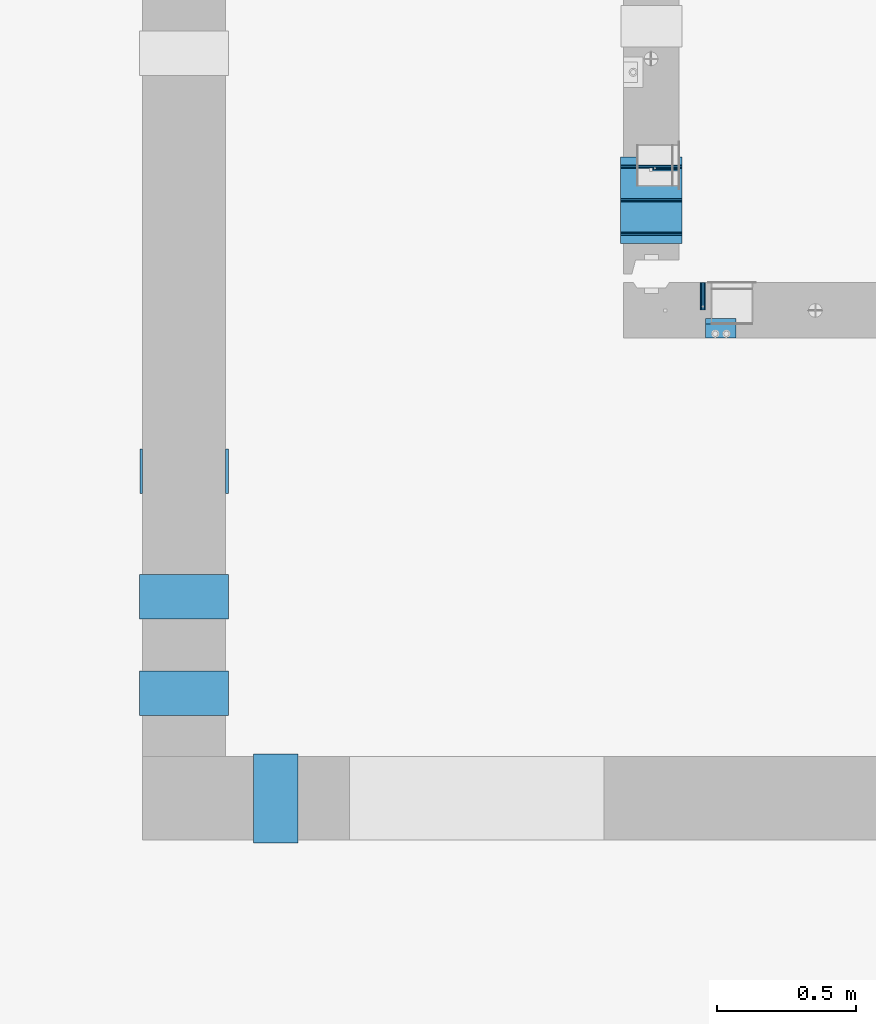
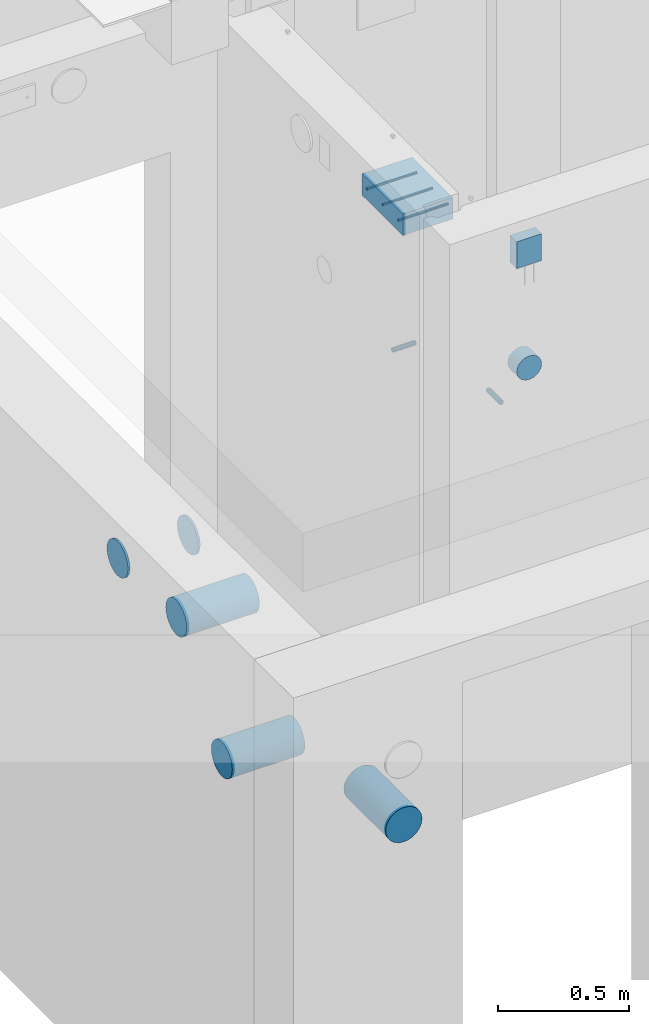
# One storey, part 88 of 264: 12 beams, 8 elements without a shape of their own.
"""IFC2X3 building model written with IfcOpenShell, lengths in millimetres."""

from ifc_helpers import new_model, si_unit, frame, origin_with_axes, place, context, subcontext, project, spatial, faceted_brep, material, type_object, element, aggregate, save


model = new_model("IFC2X3")

# Units and contexts
model_context = context("Model", 3, precision=1e-05, world=origin_with_axes())
body_context = subcontext(model_context, "Body", "Model", "MODEL_VIEW")
ifc_project = project(units=[si_unit("LENGTHUNIT", "METRE", prefix="MILLI"), si_unit("AREAUNIT", "SQUARE_METRE"), si_unit("VOLUMEUNIT", "CUBIC_METRE"), si_unit("MASSUNIT", "GRAM", prefix="KILO"), si_unit("TIMEUNIT", "SECOND"), si_unit("PLANEANGLEUNIT", "RADIAN"), si_unit("SOLIDANGLEUNIT", "STERADIAN"), si_unit("THERMODYNAMICTEMPERATUREUNIT", "DEGREE_CELSIUS"), si_unit("LUMINOUSINTENSITYUNIT", "LUMEN")], contexts=[model_context])

# Site, building, storey
site_placement = place(None, origin_with_axes())
site = spatial("IfcSite", under=ifc_project, at=site_placement, CompositionType="ELEMENT")
building_placement = place(site_placement, origin_with_axes())
building = spatial("IfcBuilding", under=site, at=building_placement, CompositionType="ELEMENT")
storey_placement = place(building_placement, origin_with_axes())
storey = spatial("IfcBuildingStorey", under=building, at=storey_placement, Name="K", CompositionType="ELEMENT", Elevation=0.0)

# Assemblies, beam
assembly_1_placement = place(storey_placement, origin_with_axes())
assembly_1 = element("IfcElementAssembly", 1, at=assembly_1_placement, inside=storey, AssemblyPlace="NOTDEFINED", PredefinedType="REINFORCEMENT_UNIT")
assembly_2_placement = place(assembly_1_placement, origin_with_axes())
assembly_2 = element("IfcElementAssembly", 2, at=assembly_2_placement, Name="Steel Assembly", AssemblyPlace="NOTDEFINED", PredefinedType="RIGID_FRAME")
ifc_material_1 = material(Name="STEEL/Steel_Undefined")
beam_type_1 = type_object("IfcBeamType", PredefinedType="NOTDEFINED")
beam_1_placement = place(assembly_2_placement, frame((15415.0048453854, 15280.0, 80575.0), z_axis=(-1.0, 3.00000001838171e-08, 0.0), x_axis=(0.0, -1.0, 0.0)))
beam_1 = element("IfcBeam", 3, at=beam_1_placement, type_object=beam_type_1, material=ifc_material_1, Name="M16", context=body_context, shape_type="Brep", body=[
    faceted_brep([(0.0, -8.49999999999272, -1.45519152283669e-11), (0.0, -7.36121593215648, 4.24999999998545), (100.000000000262, -7.36121593215648, 4.24999999998545), (100.000000000262, -8.49999999999272, -1.45519152283669e-11), (0.0, -4.24999999998545, 7.36121593216376), (100.000000000262, -4.24999999998545, 7.36121593216376), (0.0, 1.45519152283669e-11, 8.49999999998545), (100.000000000262, 1.45519152283669e-11, 8.49999999998545), (0.0, 4.25000000001455, 7.36121593216376), (100.000000000262, 4.25000000001455, 7.36121593216376), (0.0, 7.36121593217104, 4.24999999998545), (100.000000000262, 7.36121593217104, 4.24999999998545), (0.0, 8.50000000000728, 0.0), (100.000000000262, 8.50000000000728, 0.0), (0.0, 7.36121593217104, -4.25000000001455), (100.000000000262, 7.36121593217104, -4.25000000001455), (0.0, 4.25000000000728, -7.36121593219286), (100.000000000262, 4.25000000000728, -7.36121593219286), (0.0, 7.27595761418343e-12, -8.5), (100.000000000262, 7.27595761418343e-12, -8.5), (0.0, -4.24999999999272, -7.36121593217831), (100.000000000262, -4.24999999999272, -7.36121593217831), (0.0, -7.36121593215648, -4.25), (100.000000000262, -7.36121593215648, -4.25), (0.0, -10.4999999999927, -1.45519152283669e-11), (0.0, -9.09326673972828, -5.25000000001455), (100.000000000262, -9.09326673972828, -5.25000000001455), (100.000000000262, -10.4999999999927, -1.45519152283669e-11), (0.0, -5.24999999998545, -9.09326673974283), (100.000000000262, -5.24999999998545, -9.09326673974283), (0.0, 7.27595761418343e-12, -10.5), (100.000000000262, 7.27595761418343e-12, -10.5), (0.0, 5.25000000001455, -9.09326673975738), (100.000000000262, 5.25000000001455, -9.09326673975738), (0.0, 9.09326673975011, -5.25000000001455), (100.000000000262, 9.09326673975011, -5.25000000001455), (0.0, 10.5000000000073, -1.45519152283669e-11), (100.000000000262, 10.5000000000073, -1.45519152283669e-11), (0.0, 9.09326673975011, 5.25), (100.000000000262, 9.09326673975011, 5.25), (0.0, 5.25000000000728, 9.09326673972828), (100.000000000262, 5.25000000000728, 9.09326673972828), (0.0, 1.45519152283669e-11, 10.4999999999854), (100.000000000262, 1.45519152283669e-11, 10.4999999999854), (0.0, -5.24999999999272, 9.09326673972828), (100.000000000262, -5.24999999999272, 9.09326673972828), (0.0, -9.09326673972828, 5.24999999998545), (100.000000000262, -9.09326673972828, 5.24999999998545)], [[[0, 1, 2, 3]], [[1, 4, 5, 2]], [[4, 6, 7, 5]], [[6, 8, 9, 7]], [[8, 10, 11, 9]], [[10, 12, 13, 11]], [[12, 14, 15, 13]], [[14, 16, 17, 15]], [[16, 18, 19, 17]], [[18, 20, 21, 19]], [[20, 22, 23, 21]], [[22, 0, 3, 23]], [[24, 25, 26, 27]], [[25, 28, 29, 26]], [[28, 30, 31, 29]], [[30, 32, 33, 31]], [[32, 34, 35, 33]], [[34, 36, 37, 35]], [[36, 38, 39, 37]], [[38, 40, 41, 39]], [[40, 42, 43, 41]], [[42, 44, 45, 43]], [[44, 46, 47, 45]], [[46, 24, 27, 47]], [[29, 31, 33, 35, 37, 39, 41, 43, 45, 47, 27, 26], [5, 7, 9, 11, 13, 15, 17, 19, 21, 23, 3, 2]], [[46, 44, 42, 40, 38, 36, 34, 32, 30, 28, 25, 24], [22, 20, 18, 16, 14, 12, 10, 8, 6, 4, 1, 0]]]),
])
aggregate(assembly_2, [beam_1])

assembly_3_placement = place(storey_placement, origin_with_axes())
assembly_3 = element("IfcElementAssembly", 4, at=assembly_3_placement, inside=storey, AssemblyPlace="NOTDEFINED", PredefinedType="REINFORCEMENT_UNIT")
assembly_4_placement = place(assembly_3_placement, origin_with_axes())
assembly_4 = element("IfcElementAssembly", 5, at=assembly_4_placement, Name="Steel Assembly", AssemblyPlace="NOTDEFINED", PredefinedType="RIGID_FRAME")
beam_2_placement = place(assembly_4_placement, frame((15330.0, 15690.0024625975, 80575.0), z_axis=(0.0, -1.0, 0.0), x_axis=(-1.0, 3.00000001838171e-08, 0.0)))
beam_2 = element("IfcBeam", 6, at=beam_2_placement, type_object=beam_type_1, material=ifc_material_1, Name="M16", context=body_context, shape_type="Brep", body=[
    faceted_brep([(0.0, -8.49999999999272, -1.45519152283669e-11), (0.0, -7.36121593215648, 4.24999999998545), (100.000000000262, -7.36121593215648, 4.24999999998545), (100.000000000262, -8.49999999999272, -1.45519152283669e-11), (0.0, -4.24999999998545, 7.36121593216376), (100.000000000262, -4.24999999998545, 7.36121593216376), (0.0, 1.45519152283669e-11, 8.49999999998545), (100.000000000262, 1.45519152283669e-11, 8.49999999998545), (0.0, 4.25000000001455, 7.36121593216376), (100.000000000262, 4.25000000001455, 7.36121593216376), (0.0, 7.36121593217104, 4.24999999998545), (100.000000000262, 7.36121593217104, 4.24999999998545), (0.0, 8.50000000000728, 0.0), (100.000000000262, 8.50000000000728, 0.0), (0.0, 7.36121593217104, -4.25000000001455), (100.000000000262, 7.36121593217104, -4.25000000001455), (0.0, 4.25000000000728, -7.36121593219286), (100.000000000262, 4.25000000000728, -7.36121593219286), (0.0, 7.27595761418343e-12, -8.5), (100.000000000262, 7.27595761418343e-12, -8.5), (0.0, -4.24999999999272, -7.36121593217831), (100.000000000262, -4.24999999999272, -7.36121593217831), (0.0, -7.36121593215648, -4.25), (100.000000000262, -7.36121593215648, -4.25), (0.0, -10.4999999999927, -1.45519152283669e-11), (0.0, -9.09326673972828, -5.25000000001455), (100.000000000262, -9.09326673972828, -5.25000000001455), (100.000000000262, -10.4999999999927, -1.45519152283669e-11), (0.0, -5.24999999998545, -9.09326673974283), (100.000000000262, -5.24999999998545, -9.09326673974283), (0.0, 7.27595761418343e-12, -10.5), (100.000000000262, 7.27595761418343e-12, -10.5), (0.0, 5.25000000001455, -9.09326673975738), (100.000000000262, 5.25000000001455, -9.09326673975738), (0.0, 9.09326673975011, -5.25000000001455), (100.000000000262, 9.09326673975011, -5.25000000001455), (0.0, 10.5000000000073, -1.45519152283669e-11), (100.000000000262, 10.5000000000073, -1.45519152283669e-11), (0.0, 9.09326673975011, 5.25), (100.000000000262, 9.09326673975011, 5.25), (0.0, 5.25000000000728, 9.09326673972828), (100.000000000262, 5.25000000000728, 9.09326673972828), (0.0, 1.45519152283669e-11, 10.4999999999854), (100.000000000262, 1.45519152283669e-11, 10.4999999999854), (0.0, -5.24999999999272, 9.09326673972828), (100.000000000262, -5.24999999999272, 9.09326673972828), (0.0, -9.09326673972828, 5.24999999998545), (100.000000000262, -9.09326673972828, 5.24999999998545)], [[[0, 1, 2, 3]], [[1, 4, 5, 2]], [[4, 6, 7, 5]], [[6, 8, 9, 7]], [[8, 10, 11, 9]], [[10, 12, 13, 11]], [[12, 14, 15, 13]], [[14, 16, 17, 15]], [[16, 18, 19, 17]], [[18, 20, 21, 19]], [[20, 22, 23, 21]], [[22, 0, 3, 23]], [[24, 25, 26, 27]], [[25, 28, 29, 26]], [[28, 30, 31, 29]], [[30, 32, 33, 31]], [[32, 34, 35, 33]], [[34, 36, 37, 35]], [[36, 38, 39, 37]], [[38, 40, 41, 39]], [[40, 42, 43, 41]], [[42, 44, 45, 43]], [[44, 46, 47, 45]], [[46, 24, 27, 47]], [[29, 31, 33, 35, 37, 39, 41, 43, 45, 47, 27, 26], [5, 7, 9, 11, 13, 15, 17, 19, 21, 23, 3, 2]], [[46, 44, 42, 40, 38, 36, 34, 32, 30, 28, 25, 24], [22, 20, 18, 16, 14, 12, 10, 8, 6, 4, 1, 0]]]),
])
aggregate(assembly_4, [beam_2])

# Beam
ifc_material_2 = material()
beam_type_2 = type_object("IfcBeamType", Name="D110", PredefinedType="NOTDEFINED")
beam_3_placement = place(assembly_1_placement, frame((15480.0015915445, 15080.0, 80775.0), z_axis=(0.0, 0.0, 1.0), x_axis=(0.0, 1.0, 0.0)))
beam_3 = element("IfcBeam", 7, at=beam_3_placement, type_object=beam_type_2, material=ifc_material_2, ObjectType="D110", context=body_context, shape_type="Brep", body=[
    faceted_brep([(0.0, -55.0, 0.0), (0.0, -52.3081083962352, -16.9959346906253), (70.0, -52.3081083962352, -16.9959346906253), (70.0, -55.0, 0.0), (0.0, -44.4959346906217, -32.328188876083), (70.0, -44.4959346906217, -32.328188876083), (0.0, -32.3281888760866, -44.4959346906253), (70.0, -32.3281888760866, -44.4959346906253), (0.0, -16.9959346906217, -52.3081083962315), (70.0, -16.9959346906217, -52.3081083962315), (0.0, 0.0, -55.0), (70.0, 0.0, -55.0), (0.0, 16.9959346906217, -52.3081083962315), (70.0, 16.9959346906217, -52.3081083962315), (0.0, 32.3281888760866, -44.4959346906253), (70.0, 32.3281888760866, -44.4959346906253), (0.0, 44.4959346906217, -32.328188876083), (70.0, 44.4959346906217, -32.328188876083), (0.0, 52.3081083962352, -16.9959346906253), (70.0, 52.3081083962352, -16.9959346906253), (0.0, 55.0, 0.0), (70.0, 55.0, 0.0), (0.0, 52.3081083962352, 16.9959346906253), (70.0, 52.3081083962352, 16.9959346906253), (0.0, 44.4959346906217, 32.328188876083), (70.0, 44.4959346906217, 32.328188876083), (0.0, 32.3281888760866, 44.4959346906253), (70.0, 32.3281888760866, 44.4959346906253), (0.0, 16.9959346906217, 52.3081083962315), (70.0, 16.9959346906217, 52.3081083962315), (0.0, 0.0, 55.0), (70.0, 0.0, 55.0), (0.0, -16.9959346906217, 52.3081083962315), (70.0, -16.9959346906217, 52.3081083962315), (0.0, -32.3281888760866, 44.4959346906253), (70.0, -32.3281888760866, 44.4959346906253), (0.0, -44.4959346906217, 32.328188876083), (70.0, -44.4959346906217, 32.328188876083), (0.0, -52.3081083962352, 16.9959346906253), (70.0, -52.3081083962352, 16.9959346906253)], [[[0, 1, 2, 3]], [[1, 4, 5, 2]], [[4, 6, 7, 5]], [[6, 8, 9, 7]], [[8, 10, 11, 9]], [[10, 12, 13, 11]], [[12, 14, 15, 13]], [[14, 16, 17, 15]], [[16, 18, 19, 17]], [[18, 20, 21, 19]], [[20, 22, 23, 21]], [[22, 24, 25, 23]], [[24, 26, 27, 25]], [[26, 28, 29, 27]], [[28, 30, 31, 29]], [[30, 32, 33, 31]], [[32, 34, 35, 33]], [[34, 36, 37, 35]], [[36, 38, 39, 37]], [[38, 0, 3, 39]], [[5, 7, 9, 11, 13, 15, 17, 19, 21, 23, 25, 27, 29, 31, 33, 35, 37, 39, 3, 2]], [[38, 36, 34, 32, 30, 28, 26, 24, 22, 20, 18, 16, 14, 12, 10, 8, 6, 4, 1, 0]]]),
])

ifc_material_3 = material()
beam_type_3 = type_object("IfcBeamType", Name="D12", PredefinedType="NOTDEFINED")
beam_4_placement = place(assembly_3_placement, frame((15119.9999222159, 15694.9999794364, 81360.0), z_axis=(0.0, 1.0, 0.0), x_axis=(1.0, 0.0, 0.0)))
beam_4 = element("IfcBeam", 8, at=beam_4_placement, type_object=beam_type_3, material=ifc_material_3, Name="12", ObjectType="D12", context=body_context, shape_type="Brep", body=[
    faceted_brep([(0.0, -6.0, -1.45519152283669e-11), (0.0, -4.24264068712, -4.24264068713819), (219.999809265137, -4.24264068712364, -4.24264068712), (219.999809265137, -6.0, 0.0), (3.63797880709171e-12, 0.0, -6.0000000000291), (219.999809265137, 0.0, -6.0), (0.0, 4.24264068712, -4.24264068713819), (219.999809265137, 4.24264068712364, -4.24264068712), (0.0, 6.0, -1.45519152283669e-11), (219.999809265137, 6.0, 0.0), (0.0, 4.24264068712, 4.24264068709454), (219.999809265137, 4.24264068712364, 4.24264068712), (0.0, 0.0, 5.99999999998545), (219.999809265137, 0.0, 6.0), (0.0, -4.24264068712, 4.24264068709454), (219.999809265137, -4.24264068712364, 4.24264068712)], [[[0, 1, 2, 3]], [[1, 4, 5, 2]], [[4, 6, 7, 5]], [[6, 8, 9, 7]], [[8, 10, 11, 9]], [[10, 12, 13, 11]], [[12, 14, 15, 13]], [[14, 0, 3, 15]], [[5, 7, 9, 11, 13, 15, 3, 2]], [[14, 12, 10, 8, 6, 4, 1, 0]]]),
])

beam_5_placement = place(assembly_3_placement, frame((15119.9999222159, 15575.0000938773, 81360.0), z_axis=(0.0, 1.0, 0.0), x_axis=(1.0, 0.0, 0.0)))
beam_5 = element("IfcBeam", 9, at=beam_5_placement, type_object=beam_type_3, material=ifc_material_3, Name="12", ObjectType="D12", context=body_context, shape_type="Brep", body=[
    faceted_brep([(0.0, -6.0, -1.45519152283669e-11), (0.0, -4.24264068712, -4.24264068713819), (219.999809265137, -4.24264068712364, -4.24264068712), (219.999809265137, -6.0, 0.0), (3.63797880709171e-12, 0.0, -6.0000000000291), (219.999809265137, 0.0, -6.0), (0.0, 4.24264068712, -4.24264068713819), (219.999809265137, 4.24264068712364, -4.24264068712), (0.0, 6.0, -1.45519152283669e-11), (219.999809265137, 6.0, 0.0), (0.0, 4.24264068712, 4.24264068709454), (219.999809265137, 4.24264068712364, 4.24264068712), (0.0, 0.0, 5.99999999998545), (219.999809265137, 0.0, 6.0), (0.0, -4.24264068712, 4.24264068709454), (219.999809265137, -4.24264068712364, 4.24264068712)], [[[0, 1, 2, 3]], [[1, 4, 5, 2]], [[4, 6, 7, 5]], [[6, 8, 9, 7]], [[8, 10, 11, 9]], [[10, 12, 13, 11]], [[12, 14, 15, 13]], [[14, 0, 3, 15]], [[5, 7, 9, 11, 13, 15, 3, 2]], [[14, 12, 10, 8, 6, 4, 1, 0]]]),
])

beam_6_placement = place(assembly_3_placement, frame((15119.9999222159, 15455.0002083182, 81360.0), z_axis=(0.0, 1.0, 0.0), x_axis=(1.0, 0.0, 0.0)))
beam_6 = element("IfcBeam", 10, at=beam_6_placement, type_object=beam_type_3, material=ifc_material_3, Name="12", ObjectType="D12", context=body_context, shape_type="Brep", body=[
    faceted_brep([(0.0, -6.0, -1.45519152283669e-11), (0.0, -4.24264068712, -4.24264068713819), (219.999809265137, -4.24264068712364, -4.24264068712), (219.999809265137, -6.0, 0.0), (3.63797880709171e-12, 0.0, -6.0000000000291), (219.999809265137, 0.0, -6.0), (0.0, 4.24264068712, -4.24264068713819), (219.999809265137, 4.24264068712364, -4.24264068712), (0.0, 6.0, -1.45519152283669e-11), (219.999809265137, 6.0, 0.0), (0.0, 4.24264068712, 4.24264068709454), (219.999809265137, 4.24264068712364, 4.24264068712), (0.0, 0.0, 5.99999999998545), (219.999809265137, 0.0, 6.0), (0.0, -4.24264068712, 4.24264068709454), (219.999809265137, -4.24264068712364, 4.24264068712)], [[[0, 1, 2, 3]], [[1, 4, 5, 2]], [[4, 6, 7, 5]], [[6, 8, 9, 7]], [[8, 10, 11, 9]], [[10, 12, 13, 11]], [[12, 14, 15, 13]], [[14, 0, 3, 15]], [[5, 7, 9, 11, 13, 15, 3, 2]], [[14, 12, 10, 8, 6, 4, 1, 0]]]),
])

beam_type_4 = type_object("IfcBeamType", Name="125X50", PredefinedType="NOTDEFINED")
beam_7_placement = place(assembly_1_placement, frame((15534.9998715127, 15105.0, 81317.5), z_axis=(0.0, 0.0, 1.0), x_axis=(-1.0, 3.00000001838171e-08, 0.0)))
beam_7 = element("IfcBeam", 11, at=beam_7_placement, type_object=beam_type_4, material=ifc_material_2, Name="WM2", ObjectType="125X50", context=body_context, shape_type="Brep", body=[
    faceted_brep([(0.0, 25.0, -62.5), (0.0, 25.0, 62.5), (110.0, 25.0, 62.5), (110.0, 25.0, -62.5), (0.0, -25.0, 62.5), (110.0, -25.0, 62.5), (0.0, -25.0, -62.5), (110.0, -25.0, -62.5)], [[[0, 1, 2, 3]], [[1, 4, 5, 2]], [[4, 6, 7, 5]], [[6, 0, 3, 7]], [[5, 7, 3, 2]], [[0, 6, 4, 1]]]),
])

aggregate(assembly_1, [beam_7, beam_3, assembly_2])

beam_type_5 = type_object("IfcBeamType", PredefinedType="NOTDEFINED")
beam_8_placement = place(assembly_3_placement, frame((15119.9999222159, 15574.9999794364, 81360.0), z_axis=(0.0, 1.0, 0.0), x_axis=(1.0, 0.0, 0.0)))
beam_8 = element("IfcBeam", 12, at=beam_8_placement, type_object=beam_type_5, material=ifc_material_3, context=body_context, shape_type="Brep", body=[
    faceted_brep([(0.0, 50.0, -155.0), (0.0, 50.0, 155.0), (219.999809265137, 50.0, 155.0), (219.999809265137, 50.0, -155.0), (0.0, -50.0, 155.0), (219.999809265137, -50.0, 155.0), (0.0, -50.0, -155.0), (219.999809265137, -50.0, -155.0)], [[[0, 1, 2, 3]], [[1, 4, 5, 2]], [[4, 6, 7, 5]], [[6, 0, 3, 7]], [[5, 7, 3, 2]], [[6, 4, 1, 0]]]),
])

aggregate(assembly_3, [assembly_4, beam_8, beam_4, beam_5, beam_6])

# Assembly, beam
assembly_5_placement = place(storey_placement, origin_with_axes())
assembly_5 = element("IfcElementAssembly", 13, at=assembly_5_placement, inside=storey, Name="Steel Assembly", AssemblyPlace="NOTDEFINED", PredefinedType="NOTDEFINED")
ifc_material_4 = material()
beam_type_6 = type_object("IfcBeamType", Name="D160", PredefinedType="NOTDEFINED")
beam_9_placement = place(assembly_5_placement, frame((13391.1972412467, 14600.9529098868, 80910.0), z_axis=(0.0, 1.0, 0.0), x_axis=(1.0, 0.0, 0.0)))
beam_9 = element("IfcBeam", 14, at=beam_9_placement, type_object=beam_type_6, material=ifc_material_4, ObjectType="D160", context=body_context, shape_type="Brep", body=[
    faceted_brep([(308.806131594392, 0.0, 80.0), (308.806131594392, 20.7055236082088, 77.2740661031257), (308.806131594392, 40.0, 69.2820323027554), (308.806131594392, 56.5685424949188, 56.5685424949243), (308.806131594392, 69.2820323027554, 40.0), (308.806131594392, 77.2740661031276, 20.7055236082015), (308.806131594392, 80.0, 0.0), (308.806131594392, 77.2740661031276, -20.7055236082015), (308.806131594392, 69.2820323027554, -40.0), (308.806131594392, 56.5685424949188, -56.5685424949243), (308.806131594392, 40.0, -69.2820323027554), (308.806131594392, 20.7055236082088, -77.2740661031257), (308.806131594392, 0.0, -80.0), (308.806131594392, -20.7055236082088, -77.2740661031257), (308.806131594392, -40.0, -69.2820323027554), (308.806131594392, -56.5685424949188, -56.5685424949243), (308.806131594392, -69.2820323027554, -40.0), (308.806131594392, -77.2740661031276, -20.7055236082015), (308.806131594392, -80.0, 0.0), (308.806131594392, -77.2740661031276, 20.7055236082015), (308.806131594392, -69.2820323027554, 40.0), (308.806131594392, -56.5685424949188, 56.5685424949243), (308.806131594392, -40.0, 69.2820323027554), (308.806131594392, -20.7055236082088, 77.2740661031257), (318.806131594396, -69.2820323027554, -40.0), (318.806131594396, -56.5685424949188, -56.5685424949243), (318.806131594396, -40.0, -69.2820323027554), (318.806131594396, -20.7055236082088, -77.2740661031257), (318.806131594396, 0.0, -80.0), (318.806131594396, 20.7055236082088, -77.2740661031257), (318.806131594396, 40.0, -69.2820323027554), (318.806131594396, 56.5685424949188, -56.5685424949243), (318.806131594396, 69.2820323027554, -40.0), (318.806131594396, 77.2740661031276, -20.7055236082015), (318.806131594396, 80.0, 0.0), (318.806131594396, 77.2740661031276, 20.7055236082015), (318.806131594396, 69.2820323027554, 40.0), (318.806131594396, 56.5685424949188, 56.5685424949243), (318.806131594396, 40.0, 69.2820323027554), (318.806131594396, 20.7055236082088, 77.2740661031257), (318.806131594396, 0.0, 80.0), (318.806131594396, -20.7055236082088, 77.2740661031257), (318.806131594396, -40.0, 69.2820323027554), (318.806131594396, -56.5685424949188, 56.5685424949243), (318.806131594396, -69.2820323027554, 40.0), (318.806131594396, -77.2740661031276, 20.7055236082015), (318.806131594396, -80.0, 0.0), (318.806131594396, -77.2740661031276, -20.7055236082015), (8.80613159439599, 0.0, 80.0), (8.80613159439599, -20.7055236082088, 77.2740661031257), (8.80613159439599, -40.0, 69.2820323027554), (8.80613159439599, -56.5685424949188, 56.5685424949243), (8.80613159439599, -69.2820323027554, 40.0), (8.80613159439599, -77.2740661031276, 20.7055236082015), (8.80613159439599, -80.0, 0.0), (8.80613159439599, -77.2740661031276, -20.7055236082015), (8.80613159439599, -69.2820323027554, -40.0), (8.80613159439599, -56.5685424949188, -56.5685424949243), (8.80613159439599, -40.0, -69.2820323027554), (8.80613159439599, -20.7055236082088, -77.2740661031257), (8.80613159439599, 0.0, -80.0), (8.80613159439599, 20.7055236082088, -77.2740661031257), (8.80613159439599, 40.0, -69.2820323027554), (8.80613159439599, 56.5685424949188, -56.5685424949243), (8.80613159439599, 69.2820323027554, -40.0), (8.80613159439599, 77.2740661031276, -20.7055236082015), (8.80613159439599, 80.0, 0.0), (8.80613159439599, 77.2740661031276, 20.7055236082015), (8.80613159439599, 69.2820323027554, 40.0), (8.80613159439599, 56.5685424949188, 56.5685424949243), (8.80613159439599, 40.0, 69.2820323027554), (8.80613159439599, 20.7055236082088, 77.2740661031257), (0.0, -77.2740661031276, 20.7055236082015), (0.0, -69.2820323027554, 40.0), (0.0, -56.5685424949188, 56.5685424949243), (0.0, -40.0, 69.2820323027554), (0.0, -20.7055236082088, 77.2740661031257), (0.0, 0.0, 80.0), (0.0, 20.7055236082088, 77.2740661031257), (0.0, 40.0, 69.2820323027554), (0.0, 56.5685424949188, 56.5685424949243), (0.0, 69.2820323027554, 40.0), (0.0, 77.2740661031276, 20.7055236082015), (0.0, 80.0, 0.0), (0.0, 77.2740661031276, -20.7055236082015), (0.0, 69.2820323027554, -40.0), (0.0, 56.5685424949188, -56.5685424949243), (0.0, 40.0, -69.2820323027554), (0.0, 20.7055236082088, -77.2740661031257), (0.0, 0.0, -80.0), (0.0, -20.7055236082088, -77.2740661031257), (0.0, -40.0, -69.2820323027554), (0.0, -56.5685424949188, -56.5685424949243), (0.0, -69.2820323027554, -40.0), (0.0, -77.2740661031276, -20.7055236082015), (0.0, -80.0, 0.0)], [[[0, 1, 2, 3, 4, 5, 6, 7, 8, 9, 10, 11, 12, 13, 14, 15, 16, 17, 18, 19, 20, 21, 22, 23]], [[24, 25, 26, 27, 28, 29, 30, 31, 32, 33, 34, 35, 36, 37, 38, 39, 40, 41, 42, 43, 44, 45, 46, 47]], [[41, 40, 0, 23]], [[42, 41, 23, 22]], [[43, 42, 22, 21]], [[44, 43, 21, 20]], [[45, 44, 20, 19]], [[46, 45, 19, 18]], [[47, 46, 18, 17]], [[24, 47, 17, 16]], [[25, 24, 16, 15]], [[26, 25, 15, 14]], [[27, 26, 14, 13]], [[28, 27, 13, 12]], [[29, 28, 12, 11]], [[30, 29, 11, 10]], [[31, 30, 10, 9]], [[32, 31, 9, 8]], [[33, 32, 8, 7]], [[34, 33, 7, 6]], [[35, 34, 6, 5]], [[36, 35, 5, 4]], [[37, 36, 4, 3]], [[38, 37, 3, 2]], [[39, 38, 2, 1]], [[40, 39, 1, 0]], [[48, 49, 50, 51, 52, 53, 54, 55, 56, 57, 58, 59, 60, 61, 62, 63, 64, 65, 66, 67, 68, 69, 70, 71]], [[72, 73, 74, 75, 76, 77, 78, 79, 80, 81, 82, 83, 84, 85, 86, 87, 88, 89, 90, 91, 92, 93, 94, 95]], [[78, 77, 48, 71]], [[79, 78, 71, 70]], [[80, 79, 70, 69]], [[81, 80, 69, 68]], [[82, 81, 68, 67]], [[83, 82, 67, 66]], [[84, 83, 66, 65]], [[85, 84, 65, 64]], [[86, 85, 64, 63]], [[87, 86, 63, 62]], [[88, 87, 62, 61]], [[89, 88, 61, 60]], [[90, 89, 60, 59]], [[91, 90, 59, 58]], [[92, 91, 58, 57]], [[93, 92, 57, 56]], [[94, 93, 56, 55]], [[95, 94, 55, 54]], [[72, 95, 54, 53]], [[73, 72, 53, 52]], [[74, 73, 52, 51]], [[75, 74, 51, 50]], [[76, 75, 50, 49]], [[77, 76, 49, 48]]]),
])
aggregate(assembly_5, [beam_9])

assembly_6_placement = place(storey_placement, origin_with_axes())
assembly_6 = element("IfcElementAssembly", 15, at=assembly_6_placement, inside=storey, Name="Steel Assembly", AssemblyPlace="NOTDEFINED", PredefinedType="NOTDEFINED")
beam_10_placement = place(assembly_6_placement, frame((13389.528311193, 14150.1958832145, 80910.0), z_axis=(0.0, 1.0, 0.0), x_axis=(1.0, 0.0, 0.0)))
beam_10 = element("IfcBeam", 16, at=beam_10_placement, type_object=beam_type_6, material=ifc_material_4, ObjectType="D160", context=body_context, shape_type="Brep", body=[
    faceted_brep([(0.0, -80.0, 0.0), (0.0, -77.2740661031276, -20.7055236082015), (320.475061648107, -77.2740661031276, -20.7055236082015), (320.475061648107, -80.0, 0.0), (0.0, -69.2820323027554, -40.0), (320.475061648107, -69.2820323027554, -40.0), (0.0, -56.5685424949188, -56.5685424949243), (320.475061648107, -56.5685424949188, -56.5685424949243), (0.0, -40.0, -69.2820323027554), (320.475061648107, -40.0, -69.2820323027554), (0.0, -20.7055236082088, -77.2740661031257), (320.475061648107, -20.7055236082088, -77.2740661031257), (0.0, 0.0, -80.0), (320.475061648107, 0.0, -80.0), (0.0, 20.7055236082088, -77.2740661031257), (320.475061648107, 20.7055236082088, -77.2740661031257), (0.0, 40.0, -69.2820323027554), (320.475061648107, 40.0, -69.2820323027554), (0.0, 56.5685424949188, -56.5685424949243), (320.475061648107, 56.5685424949188, -56.5685424949243), (0.0, 69.2820323027554, -40.0), (320.475061648107, 69.2820323027554, -40.0), (0.0, 77.2740661031276, -20.7055236082015), (320.475061648107, 77.2740661031276, -20.7055236082015), (0.0, 80.0, 0.0), (320.475061648107, 80.0, 0.0), (0.0, 77.2740661031276, 20.7055236082015), (320.475061648107, 77.2740661031276, 20.7055236082015), (0.0, 69.2820323027554, 40.0), (320.475061648107, 69.2820323027554, 40.0), (0.0, 56.5685424949188, 56.5685424949243), (320.475061648107, 56.5685424949188, 56.5685424949243), (0.0, 40.0, 69.2820323027554), (320.475061648107, 40.0, 69.2820323027554), (0.0, 20.7055236082088, 77.2740661031257), (320.475061648107, 20.7055236082088, 77.2740661031257), (0.0, 0.0, 80.0), (320.475061648107, 0.0, 80.0), (0.0, -20.7055236082088, 77.2740661031257), (320.475061648107, -20.7055236082088, 77.2740661031257), (0.0, -40.0, 69.2820323027554), (320.475061648107, -40.0, 69.2820323027554), (0.0, -56.5685424949188, 56.5685424949243), (320.475061648107, -56.5685424949188, 56.5685424949243), (0.0, -69.2820323027554, 40.0), (320.475061648107, -69.2820323027554, 40.0), (0.0, -77.2740661031276, 20.7055236082015), (320.475061648107, -77.2740661031276, 20.7055236082015)], [[[0, 1, 2, 3]], [[1, 4, 5, 2]], [[4, 6, 7, 5]], [[6, 8, 9, 7]], [[8, 10, 11, 9]], [[10, 12, 13, 11]], [[12, 14, 15, 13]], [[14, 16, 17, 15]], [[16, 18, 19, 17]], [[18, 20, 21, 19]], [[20, 22, 23, 21]], [[22, 24, 25, 23]], [[24, 26, 27, 25]], [[26, 28, 29, 27]], [[28, 30, 31, 29]], [[30, 32, 33, 31]], [[32, 34, 35, 33]], [[34, 36, 37, 35]], [[36, 38, 39, 37]], [[38, 40, 41, 39]], [[40, 42, 43, 41]], [[42, 44, 45, 43]], [[44, 46, 47, 45]], [[46, 0, 3, 47]], [[5, 7, 9, 11, 13, 15, 17, 19, 21, 23, 25, 27, 29, 31, 33, 35, 37, 39, 41, 43, 45, 47, 3, 2]], [[46, 44, 42, 40, 38, 36, 34, 32, 30, 28, 26, 24, 22, 20, 18, 16, 14, 12, 10, 8, 6, 4, 1, 0]]]),
])
aggregate(assembly_6, [beam_10])

assembly_7_placement = place(storey_placement, origin_with_axes())
assembly_7 = element("IfcElementAssembly", 17, at=assembly_7_placement, inside=storey, Name="Steel Assembly", AssemblyPlace="NOTDEFINED", PredefinedType="NOTDEFINED")
beam_11_placement = place(assembly_7_placement, frame((13390.2588257194, 13803.5896286368, 80460.0), z_axis=(0.0, 1.0, 0.0), x_axis=(1.0, 0.0, 0.0)))
beam_11 = element("IfcBeam", 18, at=beam_11_placement, type_object=beam_type_6, material=ifc_material_4, ObjectType="D160", context=body_context, shape_type="Brep", body=[
    faceted_brep([(0.0, -80.0, 0.0), (0.0, -77.2740661031276, -20.7055236082015), (319.74454712174, -77.2740661031276, -20.7055236082015), (319.74454712174, -80.0, 0.0), (0.0, -69.2820323027554, -40.0), (319.74454712174, -69.2820323027554, -40.0), (0.0, -56.5685424949188, -56.5685424949243), (319.74454712174, -56.5685424949188, -56.5685424949243), (0.0, -40.0, -69.2820323027554), (319.74454712174, -40.0, -69.2820323027554), (0.0, -20.7055236082088, -77.2740661031257), (319.74454712174, -20.7055236082088, -77.2740661031257), (0.0, 0.0, -80.0), (319.74454712174, 0.0, -80.0), (0.0, 20.7055236082088, -77.2740661031257), (319.74454712174, 20.7055236082088, -77.2740661031257), (0.0, 40.0, -69.2820323027554), (319.74454712174, 40.0, -69.2820323027554), (0.0, 56.5685424949188, -56.5685424949243), (319.74454712174, 56.5685424949188, -56.5685424949243), (0.0, 69.2820323027554, -40.0), (319.74454712174, 69.2820323027554, -40.0), (0.0, 77.2740661031276, -20.7055236082015), (319.74454712174, 77.2740661031276, -20.7055236082015), (0.0, 80.0, 0.0), (319.74454712174, 80.0, 0.0), (0.0, 77.2740661031276, 20.7055236082015), (319.74454712174, 77.2740661031276, 20.7055236082015), (0.0, 69.2820323027554, 40.0), (319.74454712174, 69.2820323027554, 40.0), (0.0, 56.5685424949188, 56.5685424949243), (319.74454712174, 56.5685424949188, 56.5685424949243), (0.0, 40.0, 69.2820323027554), (319.74454712174, 40.0, 69.2820323027554), (0.0, 20.7055236082088, 77.2740661031257), (319.74454712174, 20.7055236082088, 77.2740661031257), (0.0, 0.0, 80.0), (319.74454712174, 0.0, 80.0), (0.0, -20.7055236082088, 77.2740661031257), (319.74454712174, -20.7055236082088, 77.2740661031257), (0.0, -40.0, 69.2820323027554), (319.74454712174, -40.0, 69.2820323027554), (0.0, -56.5685424949188, 56.5685424949243), (319.74454712174, -56.5685424949188, 56.5685424949243), (0.0, -69.2820323027554, 40.0), (319.74454712174, -69.2820323027554, 40.0), (0.0, -77.2740661031276, 20.7055236082015), (319.74454712174, -77.2740661031276, 20.7055236082015)], [[[0, 1, 2, 3]], [[1, 4, 5, 2]], [[4, 6, 7, 5]], [[6, 8, 9, 7]], [[8, 10, 11, 9]], [[10, 12, 13, 11]], [[12, 14, 15, 13]], [[14, 16, 17, 15]], [[16, 18, 19, 17]], [[18, 20, 21, 19]], [[20, 22, 23, 21]], [[22, 24, 25, 23]], [[24, 26, 27, 25]], [[26, 28, 29, 27]], [[28, 30, 31, 29]], [[30, 32, 33, 31]], [[32, 34, 35, 33]], [[34, 36, 37, 35]], [[36, 38, 39, 37]], [[38, 40, 41, 39]], [[40, 42, 43, 41]], [[42, 44, 45, 43]], [[44, 46, 47, 45]], [[46, 0, 3, 47]], [[5, 7, 9, 11, 13, 15, 17, 19, 21, 23, 25, 27, 29, 31, 33, 35, 37, 39, 41, 43, 45, 47, 3, 2]], [[46, 44, 42, 40, 38, 36, 34, 32, 30, 28, 26, 24, 22, 20, 18, 16, 14, 12, 10, 8, 6, 4, 1, 0]]]),
])
aggregate(assembly_7, [beam_11])

assembly_8_placement = place(storey_placement, origin_with_axes())
assembly_8 = element("IfcElementAssembly", 19, at=assembly_8_placement, inside=storey, Name="Steel Assembly", AssemblyPlace="NOTDEFINED", PredefinedType="NOTDEFINED")
beam_12_placement = place(assembly_8_placement, frame((13880.2688583732, 13265.0003799796, 80310.0), z_axis=(-1.0, 3.00000001838171e-08, 0.0), x_axis=(0.0, 1.0, 0.0)))
beam_12 = element("IfcBeam", 20, at=beam_12_placement, type_object=beam_type_6, material=ifc_material_4, ObjectType="D160", context=body_context, shape_type="Brep", body=[
    faceted_brep([(0.0, -80.0, 0.0), (0.0, -77.2740661031276, -20.7055236082015), (320.002606876909, -77.2740661031276, -20.7055236082015), (320.002606876909, -80.0, 0.0), (0.0, -69.2820323027554, -40.0), (320.002606876909, -69.2820323027554, -40.0), (0.0, -56.5685424949188, -56.5685424949243), (320.002606876909, -56.5685424949188, -56.5685424949243), (0.0, -40.0, -69.2820323027554), (320.002606876909, -40.0, -69.2820323027554), (0.0, -20.7055236082088, -77.2740661031257), (320.002606876909, -20.7055236082088, -77.2740661031257), (0.0, 0.0, -80.0), (320.002606876909, 0.0, -80.0), (0.0, 20.7055236082088, -77.2740661031257), (320.002606876909, 20.7055236082088, -77.2740661031257), (0.0, 40.0, -69.2820323027554), (320.002606876909, 40.0, -69.2820323027554), (0.0, 56.5685424949188, -56.5685424949243), (320.002606876909, 56.5685424949188, -56.5685424949243), (0.0, 69.2820323027554, -40.0), (320.002606876909, 69.2820323027554, -40.0), (0.0, 77.2740661031276, -20.7055236082015), (320.002606876909, 77.2740661031276, -20.7055236082015), (0.0, 80.0, 0.0), (320.002606876909, 80.0, 0.0), (0.0, 77.2740661031276, 20.7055236082015), (320.002606876909, 77.2740661031276, 20.7055236082015), (0.0, 69.2820323027554, 40.0), (320.002606876909, 69.2820323027554, 40.0), (0.0, 56.5685424949188, 56.5685424949243), (320.002606876909, 56.5685424949188, 56.5685424949243), (0.0, 40.0, 69.2820323027554), (320.002606876909, 40.0, 69.2820323027554), (0.0, 20.7055236082088, 77.2740661031257), (320.002606876909, 20.7055236082088, 77.2740661031257), (0.0, 0.0, 80.0), (320.002606876909, 0.0, 80.0), (0.0, -20.7055236082088, 77.2740661031257), (320.002606876909, -20.7055236082088, 77.2740661031257), (0.0, -40.0, 69.2820323027554), (320.002606876909, -40.0, 69.2820323027554), (0.0, -56.5685424949188, 56.5685424949243), (320.002606876909, -56.5685424949188, 56.5685424949243), (0.0, -69.2820323027554, 40.0), (320.002606876909, -69.2820323027554, 40.0), (0.0, -77.2740661031276, 20.7055236082015), (320.002606876909, -77.2740661031276, 20.7055236082015)], [[[0, 1, 2, 3]], [[1, 4, 5, 2]], [[4, 6, 7, 5]], [[6, 8, 9, 7]], [[8, 10, 11, 9]], [[10, 12, 13, 11]], [[12, 14, 15, 13]], [[14, 16, 17, 15]], [[16, 18, 19, 17]], [[18, 20, 21, 19]], [[20, 22, 23, 21]], [[22, 24, 25, 23]], [[24, 26, 27, 25]], [[26, 28, 29, 27]], [[28, 30, 31, 29]], [[30, 32, 33, 31]], [[32, 34, 35, 33]], [[34, 36, 37, 35]], [[36, 38, 39, 37]], [[38, 40, 41, 39]], [[40, 42, 43, 41]], [[42, 44, 45, 43]], [[44, 46, 47, 45]], [[46, 0, 3, 47]], [[5, 7, 9, 11, 13, 15, 17, 19, 21, 23, 25, 27, 29, 31, 33, 35, 37, 39, 41, 43, 45, 47, 3, 2]], [[46, 44, 42, 40, 38, 36, 34, 32, 30, 28, 26, 24, 22, 20, 18, 16, 14, 12, 10, 8, 6, 4, 1, 0]]]),
])
aggregate(assembly_8, [beam_12])

save(model, "model.ifc")
